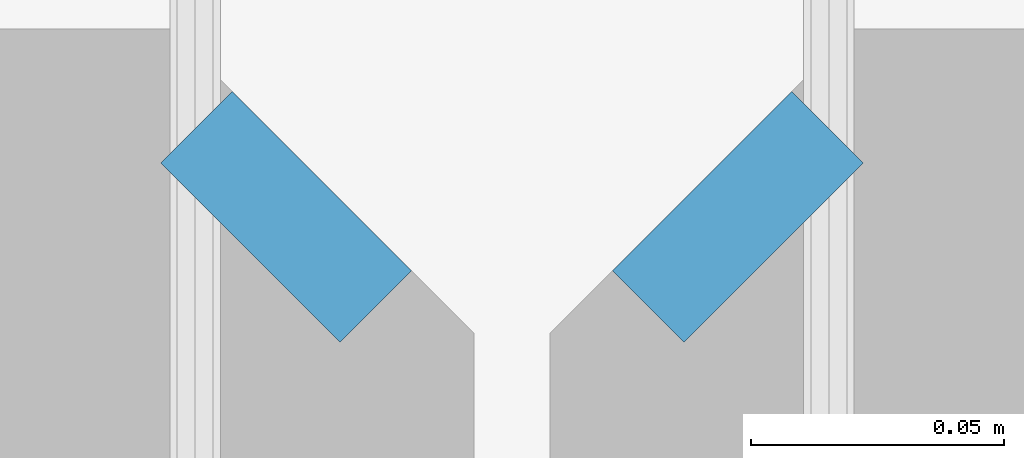
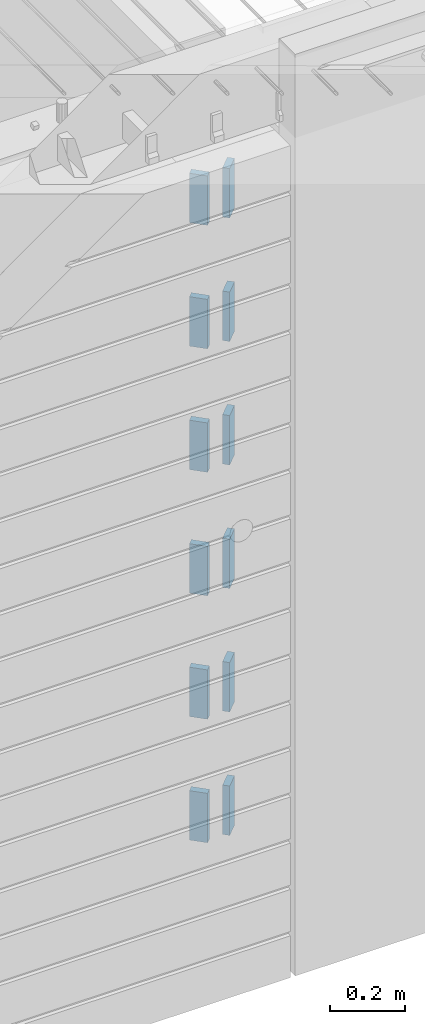
# One storey, part 205 of 334: 12 plates, 14 elements without a shape of their own.
"""IFC2X3 building model written with IfcOpenShell, lengths in millimetres."""

from ifc_helpers import new_model, si_unit, frame, origin_with_axes, place, context, subcontext, project, spatial, faceted_brep, material, type_object, element, aggregate, save


model = new_model("IFC2X3")

# Units and contexts
model_context = context("Model", 3, precision=1e-05, world=origin_with_axes())
body_context = subcontext(model_context, "Body", "Model", "MODEL_VIEW")
ifc_project = project(units=[si_unit("LENGTHUNIT", "METRE", prefix="MILLI"), si_unit("AREAUNIT", "SQUARE_METRE"), si_unit("VOLUMEUNIT", "CUBIC_METRE"), si_unit("MASSUNIT", "GRAM", prefix="KILO"), si_unit("TIMEUNIT", "SECOND"), si_unit("PLANEANGLEUNIT", "RADIAN"), si_unit("SOLIDANGLEUNIT", "STERADIAN"), si_unit("THERMODYNAMICTEMPERATUREUNIT", "DEGREE_CELSIUS"), si_unit("LUMINOUSINTENSITYUNIT", "LUMEN")], contexts=[model_context])

# Site, building, storey
site_placement = place(None, origin_with_axes())
site = spatial("IfcSite", under=ifc_project, at=site_placement, CompositionType="ELEMENT")
building_placement = place(site_placement, origin_with_axes())
building = spatial("IfcBuilding", under=site, at=building_placement, CompositionType="ELEMENT")
storey_placement = place(building_placement, origin_with_axes())
storey = spatial("IfcBuildingStorey", under=building, at=storey_placement, Name="3", CompositionType="ELEMENT", Elevation=0.0)

# Assemblies, plates
assembly_1_placement = place(storey_placement, origin_with_axes())
assembly_1 = element("IfcElementAssembly", 1, at=assembly_1_placement, inside=storey, AssemblyPlace="NOTDEFINED", PredefinedType="REINFORCEMENT_UNIT")
assembly_2_placement = place(assembly_1_placement, origin_with_axes())
assembly_2 = element("IfcElementAssembly", 2, at=assembly_2_placement, Name="Steel Assembly", AssemblyPlace="NOTDEFINED", PredefinedType="RIGID_FRAME")
ifc_material = material(Name="STEEL/Steel_Undefined")
plate_type = type_object("IfcPlateType", PredefinedType="NOTDEFINED")
plate_1_placement = place(assembly_2_placement, frame((28641.4644660941, 7938.1801948466, 90042.5), z_axis=(-0.707106781186547, 0.707106781186548, 0.0), x_axis=(0.707106781186557, 0.707106781186538, 0.0)))
plate_1 = element("IfcPlate", 3, at=plate_1_placement, type_object=plate_type, material=ifc_material, Name="VL_080", context=body_context, shape_type="Brep", body=[
    faceted_brep([(0.0, -80.0, 0.0), (0.0, -80.0, 20.0), (0.0, 80.0, 20.0), (0.0, 80.0, 0.0), (50.0, -80.0, 20.0), (50.0, 80.0, 20.0), (50.0, -80.0, 0.0), (50.0, 80.0, 0.0)], [[[0, 1, 2, 3]], [[1, 4, 5, 2]], [[4, 6, 7, 5]], [[6, 0, 3, 7]], [[5, 7, 3, 2]], [[6, 4, 1, 0]]]),
])
aggregate(assembly_2, [plate_1])
assembly_3_placement = place(assembly_1_placement, origin_with_axes())
assembly_3 = element("IfcElementAssembly", 4, at=assembly_3_placement, Name="Steel Assembly", AssemblyPlace="NOTDEFINED", PredefinedType="RIGID_FRAME")
plate_2_placement = place(assembly_3_placement, frame((28641.4644660941, 7938.1801948466, 89642.5), z_axis=(-0.707106781186547, 0.707106781186548, 0.0), x_axis=(0.707106781186557, 0.707106781186538, 0.0)))
plate_2 = element("IfcPlate", 5, at=plate_2_placement, type_object=plate_type, material=ifc_material, Name="VL_080", context=body_context, shape_type="Brep", body=[
    faceted_brep([(0.0, -80.0, 0.0), (0.0, -80.0, 20.0), (0.0, 80.0, 20.0), (0.0, 80.0, 0.0), (50.0, -80.0, 20.0), (50.0, 80.0, 20.0), (50.0, -80.0, 0.0), (50.0, 80.0, 0.0)], [[[0, 1, 2, 3]], [[1, 4, 5, 2]], [[4, 6, 7, 5]], [[6, 0, 3, 7]], [[5, 7, 3, 2]], [[6, 4, 1, 0]]]),
])
aggregate(assembly_3, [plate_2])
assembly_4_placement = place(assembly_1_placement, origin_with_axes())
assembly_4 = element("IfcElementAssembly", 6, at=assembly_4_placement, Name="Steel Assembly", AssemblyPlace="NOTDEFINED", PredefinedType="RIGID_FRAME")
plate_3_placement = place(assembly_4_placement, frame((28641.4644660941, 7938.1801948466, 89242.5), z_axis=(-0.707106781186547, 0.707106781186548, 0.0), x_axis=(0.707106781186557, 0.707106781186538, 0.0)))
plate_3 = element("IfcPlate", 7, at=plate_3_placement, type_object=plate_type, material=ifc_material, Name="VL_080", context=body_context, shape_type="Brep", body=[
    faceted_brep([(0.0, -80.0, 0.0), (0.0, -80.0, 20.0), (0.0, 80.0, 20.0), (0.0, 80.0, 0.0), (50.0, -80.0, 20.0), (50.0, 80.0, 20.0), (50.0, -80.0, 0.0), (50.0, 80.0, 0.0)], [[[0, 1, 2, 3]], [[1, 4, 5, 2]], [[4, 6, 7, 5]], [[6, 0, 3, 7]], [[5, 7, 3, 2]], [[6, 4, 1, 0]]]),
])
aggregate(assembly_4, [plate_3])

assembly_5_placement = place(storey_placement, origin_with_axes())
assembly_5 = element("IfcElementAssembly", 8, at=assembly_5_placement, inside=storey, AssemblyPlace="NOTDEFINED", PredefinedType="REINFORCEMENT_UNIT")
assembly_6_placement = place(assembly_5_placement, origin_with_axes())
assembly_6 = element("IfcElementAssembly", 9, at=assembly_6_placement, Name="Steel Assembly", AssemblyPlace="NOTDEFINED", PredefinedType="RIGID_FRAME")
plate_4_placement = place(assembly_6_placement, frame((28538.1801948466, 7973.53553390593, 90042.5), z_axis=(0.707106781186557, 0.707106781186538, 0.0), x_axis=(0.707106781186557, -0.707106781186538, 0.0)))
plate_4 = element("IfcPlate", 10, at=plate_4_placement, type_object=plate_type, material=ifc_material, Name="VL_080", context=body_context, shape_type="Brep", body=[
    faceted_brep([(0.0, -80.0, 0.0), (0.0, -80.0, 20.0), (0.0, 80.0, 20.0), (0.0, 80.0, 0.0), (50.0, -80.0, 20.0), (50.0, 80.0, 20.0), (50.0, -80.0, 0.0), (50.0, 80.0, 0.0)], [[[0, 1, 2, 3]], [[1, 4, 5, 2]], [[4, 6, 7, 5]], [[6, 0, 3, 7]], [[5, 7, 3, 2]], [[6, 4, 1, 0]]]),
])
aggregate(assembly_6, [plate_4])
assembly_7_placement = place(assembly_5_placement, origin_with_axes())
assembly_7 = element("IfcElementAssembly", 11, at=assembly_7_placement, Name="Steel Assembly", AssemblyPlace="NOTDEFINED", PredefinedType="RIGID_FRAME")
plate_5_placement = place(assembly_7_placement, frame((28538.1801948466, 7973.53553390593, 89642.5), z_axis=(0.707106781186557, 0.707106781186538, 0.0), x_axis=(0.707106781186557, -0.707106781186538, 0.0)))
plate_5 = element("IfcPlate", 12, at=plate_5_placement, type_object=plate_type, material=ifc_material, Name="VL_080", context=body_context, shape_type="Brep", body=[
    faceted_brep([(0.0, -80.0, 0.0), (0.0, -80.0, 20.0), (0.0, 80.0, 20.0), (0.0, 80.0, 0.0), (50.0, -80.0, 20.0), (50.0, 80.0, 20.0), (50.0, -80.0, 0.0), (50.0, 80.0, 0.0)], [[[0, 1, 2, 3]], [[1, 4, 5, 2]], [[4, 6, 7, 5]], [[6, 0, 3, 7]], [[5, 7, 3, 2]], [[6, 4, 1, 0]]]),
])
aggregate(assembly_7, [plate_5])
assembly_8_placement = place(assembly_5_placement, origin_with_axes())
assembly_8 = element("IfcElementAssembly", 13, at=assembly_8_placement, Name="Steel Assembly", AssemblyPlace="NOTDEFINED", PredefinedType="RIGID_FRAME")
plate_6_placement = place(assembly_8_placement, frame((28538.1801948466, 7973.53553390593, 89242.5), z_axis=(0.707106781186557, 0.707106781186538, 0.0), x_axis=(0.707106781186557, -0.707106781186538, 0.0)))
plate_6 = element("IfcPlate", 14, at=plate_6_placement, type_object=plate_type, material=ifc_material, Name="VL_080", context=body_context, shape_type="Brep", body=[
    faceted_brep([(0.0, -80.0, 0.0), (0.0, -80.0, 20.0), (0.0, 80.0, 20.0), (0.0, 80.0, 0.0), (50.0, -80.0, 20.0), (50.0, 80.0, 20.0), (50.0, -80.0, 0.0), (50.0, 80.0, 0.0)], [[[0, 1, 2, 3]], [[1, 4, 5, 2]], [[4, 6, 7, 5]], [[6, 0, 3, 7]], [[5, 7, 3, 2]], [[6, 4, 1, 0]]]),
])
aggregate(assembly_8, [plate_6])

# Assembly, plate
assembly_9_placement = place(assembly_1_placement, origin_with_axes())
assembly_9 = element("IfcElementAssembly", 15, at=assembly_9_placement, Name="Steel Assembly", AssemblyPlace="NOTDEFINED", PredefinedType="RIGID_FRAME")
plate_7_placement = place(assembly_9_placement, frame((28641.4644660941, 7938.18019484659, 88842.5), z_axis=(-0.707106781186547, 0.707106781186548, 0.0), x_axis=(0.707106781186557, 0.707106781186538, 0.0)))
plate_7 = element("IfcPlate", 16, at=plate_7_placement, type_object=plate_type, material=ifc_material, Name="VL_080", context=body_context, shape_type="Brep", body=[
    faceted_brep([(0.0, -80.0, 0.0), (0.0, -80.0, 20.0), (0.0, 80.0, 20.0), (0.0, 80.0, 0.0), (50.0, -80.0, 20.0), (50.0, 80.0, 20.0), (50.0, -80.0, 0.0), (50.0, 80.0, 0.0)], [[[0, 1, 2, 3]], [[1, 4, 5, 2]], [[4, 6, 7, 5]], [[6, 0, 3, 7]], [[5, 7, 3, 2]], [[6, 4, 1, 0]]]),
])
aggregate(assembly_9, [plate_7])

assembly_10_placement = place(assembly_1_placement, origin_with_axes())
assembly_10 = element("IfcElementAssembly", 17, at=assembly_10_placement, Name="Steel Assembly", AssemblyPlace="NOTDEFINED", PredefinedType="RIGID_FRAME")
plate_8_placement = place(assembly_10_placement, frame((28641.4644660941, 7938.1801948466, 88442.5), z_axis=(-0.707106781186547, 0.707106781186548, 0.0), x_axis=(0.707106781186557, 0.707106781186538, 0.0)))
plate_8 = element("IfcPlate", 18, at=plate_8_placement, type_object=plate_type, material=ifc_material, Name="VL_080", context=body_context, shape_type="Brep", body=[
    faceted_brep([(0.0, -80.0, 0.0), (0.0, -80.0, 20.0), (0.0, 80.0, 20.0), (0.0, 80.0, 0.0), (50.0, -80.0, 20.0), (50.0, 80.0, 20.0), (50.0, -80.0, 0.0), (50.0, 80.0, 0.0)], [[[0, 1, 2, 3]], [[1, 4, 5, 2]], [[4, 6, 7, 5]], [[6, 0, 3, 7]], [[5, 7, 3, 2]], [[6, 4, 1, 0]]]),
])
aggregate(assembly_10, [plate_8])

# Assembly
assembly_11_placement = place(assembly_1_placement, origin_with_axes())
assembly_11 = element("IfcElementAssembly", 19, at=assembly_11_placement, Name="Steel Assembly", AssemblyPlace="NOTDEFINED", PredefinedType="RIGID_FRAME")

aggregate(assembly_1, [assembly_2, assembly_3, assembly_4, assembly_9, assembly_10, assembly_11])

# Plate
plate_9_placement = place(assembly_11_placement, frame((28641.4644660941, 7938.1801948466, 88042.5), z_axis=(-0.707106781186547, 0.707106781186548, 0.0), x_axis=(0.707106781186557, 0.707106781186538, 0.0)))
plate_9 = element("IfcPlate", 20, at=plate_9_placement, type_object=plate_type, material=ifc_material, Name="VL_080", context=body_context, shape_type="Brep", body=[
    faceted_brep([(0.0, -80.0, 0.0), (0.0, -80.0, 20.0), (0.0, 80.0, 20.0), (0.0, 80.0, 0.0), (50.0, -80.0, 20.0), (50.0, 80.0, 20.0), (50.0, -80.0, 0.0), (50.0, 80.0, 0.0)], [[[0, 1, 2, 3]], [[1, 4, 5, 2]], [[4, 6, 7, 5]], [[6, 0, 3, 7]], [[5, 7, 3, 2]], [[6, 4, 1, 0]]]),
])

aggregate(assembly_11, [plate_9])

# Assembly, plate
assembly_12_placement = place(assembly_5_placement, origin_with_axes())
assembly_12 = element("IfcElementAssembly", 21, at=assembly_12_placement, Name="Steel Assembly", AssemblyPlace="NOTDEFINED", PredefinedType="RIGID_FRAME")
plate_10_placement = place(assembly_12_placement, frame((28538.1801948466, 7973.53553390592, 88842.5), z_axis=(0.707106781186557, 0.707106781186538, 0.0), x_axis=(0.707106781186557, -0.707106781186538, 0.0)))
plate_10 = element("IfcPlate", 22, at=plate_10_placement, type_object=plate_type, material=ifc_material, Name="VL_080", context=body_context, shape_type="Brep", body=[
    faceted_brep([(0.0, -80.0, 0.0), (0.0, -80.0, 20.0), (0.0, 80.0, 20.0), (0.0, 80.0, 0.0), (50.0, -80.0, 20.0), (50.0, 80.0, 20.0), (50.0, -80.0, 0.0), (50.0, 80.0, 0.0)], [[[0, 1, 2, 3]], [[1, 4, 5, 2]], [[4, 6, 7, 5]], [[6, 0, 3, 7]], [[5, 7, 3, 2]], [[6, 4, 1, 0]]]),
])
aggregate(assembly_12, [plate_10])

assembly_13_placement = place(assembly_5_placement, origin_with_axes())
assembly_13 = element("IfcElementAssembly", 23, at=assembly_13_placement, Name="Steel Assembly", AssemblyPlace="NOTDEFINED", PredefinedType="RIGID_FRAME")
plate_11_placement = place(assembly_13_placement, frame((28538.1801948466, 7973.53553390591, 88442.5), z_axis=(0.707106781186557, 0.707106781186538, 0.0), x_axis=(0.707106781186557, -0.707106781186538, 0.0)))
plate_11 = element("IfcPlate", 24, at=plate_11_placement, type_object=plate_type, material=ifc_material, Name="VL_080", context=body_context, shape_type="Brep", body=[
    faceted_brep([(0.0, -80.0, 0.0), (0.0, -80.0, 20.0), (0.0, 80.0, 20.0), (0.0, 80.0, 0.0), (50.0, -80.0, 20.0), (50.0, 80.0, 20.0), (50.0, -80.0, 0.0), (50.0, 80.0, 0.0)], [[[0, 1, 2, 3]], [[1, 4, 5, 2]], [[4, 6, 7, 5]], [[6, 0, 3, 7]], [[5, 7, 3, 2]], [[6, 4, 1, 0]]]),
])
aggregate(assembly_13, [plate_11])

# Assembly
assembly_14_placement = place(assembly_5_placement, origin_with_axes())
assembly_14 = element("IfcElementAssembly", 25, at=assembly_14_placement, Name="Steel Assembly", AssemblyPlace="NOTDEFINED", PredefinedType="RIGID_FRAME")

aggregate(assembly_5, [assembly_6, assembly_7, assembly_8, assembly_12, assembly_13, assembly_14])

# Plate
plate_12_placement = place(assembly_14_placement, frame((28538.1801948466, 7973.53553390592, 88042.5), z_axis=(0.707106781186557, 0.707106781186538, 0.0), x_axis=(0.707106781186557, -0.707106781186538, 0.0)))
plate_12 = element("IfcPlate", 26, at=plate_12_placement, type_object=plate_type, material=ifc_material, Name="VL_080", context=body_context, shape_type="Brep", body=[
    faceted_brep([(0.0, -80.0, 0.0), (0.0, -80.0, 20.0), (0.0, 80.0, 20.0), (0.0, 80.0, 0.0), (50.0, -80.0, 20.0), (50.0, 80.0, 20.0), (50.0, -80.0, 0.0), (50.0, 80.0, 0.0)], [[[0, 1, 2, 3]], [[1, 4, 5, 2]], [[4, 6, 7, 5]], [[6, 0, 3, 7]], [[5, 7, 3, 2]], [[6, 4, 1, 0]]]),
])

aggregate(assembly_14, [plate_12])

save(model, "model.ifc")
